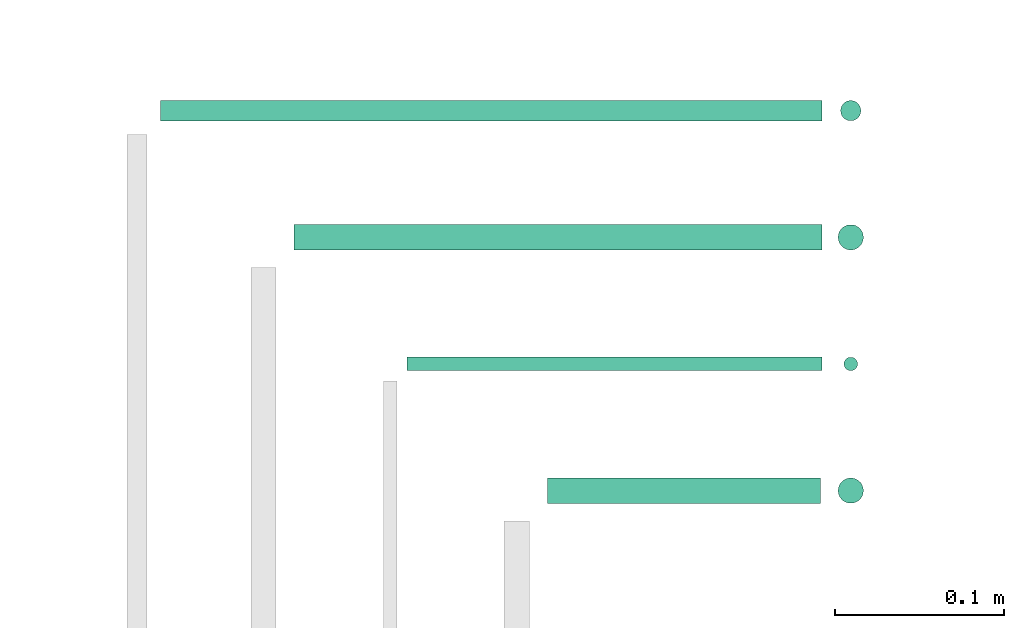
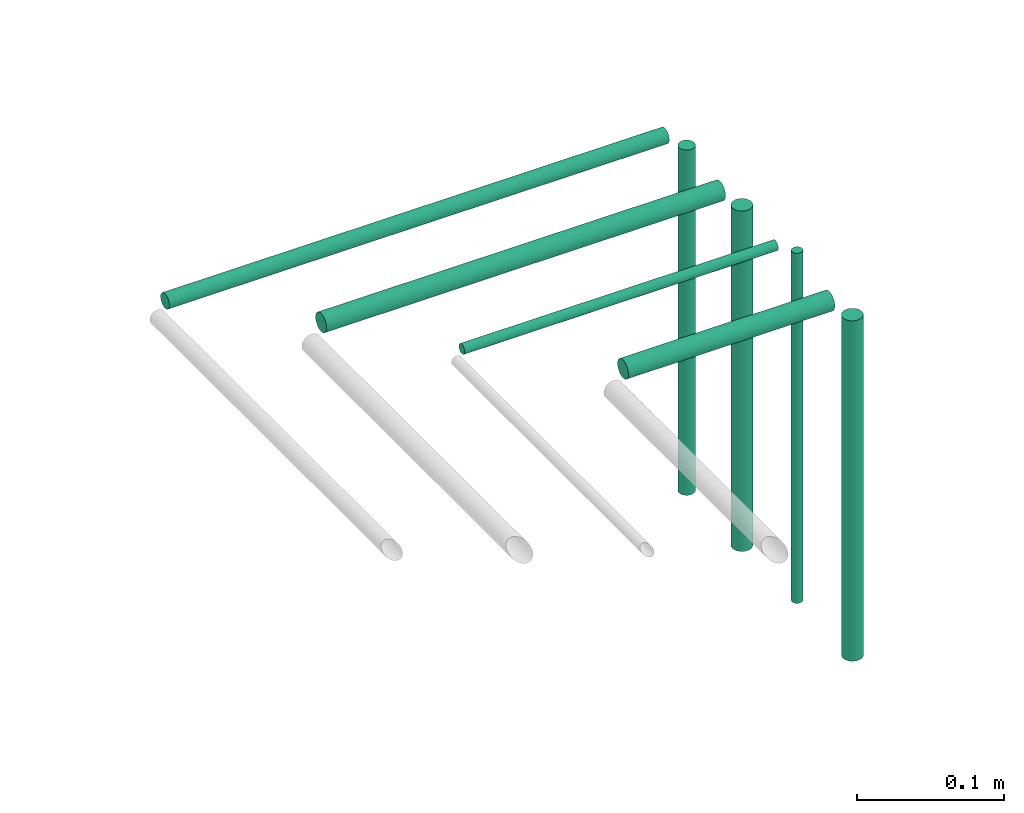
# One storey, part 35 of 65: 8 flow segments.
"""IFC2X3 building model written with IfcOpenShell, lengths in millimetres."""

from ifc_helpers import new_model, entity, si_unit, converted_unit, derived_unit, direction, frame, origin, origin_2d_with_axis, place, context, subcontext, project, spatial, circle, extrude, type_object, element, save


model = new_model("IFC2X3")

# Units and contexts
model_context = context("Model", 3, precision=0.01, world=origin(), true_north=direction((6.12303176911189e-17, 1.0)))
body_context = subcontext(model_context, "Body", "Model", "MODEL_VIEW")
ifc_project = project(units=[si_unit("LENGTHUNIT", "METRE", prefix="MILLI"), si_unit("AREAUNIT", "SQUARE_METRE"), si_unit("VOLUMEUNIT", "CUBIC_METRE"), converted_unit("PLANEANGLEUNIT", "DEGREE", entity("IfcRatioMeasure", 0.0174532925199433), si_unit("PLANEANGLEUNIT", "RADIAN"), dimensions=[0, 0, 0, 0, 0, 0, 0]), si_unit("MASSUNIT", "GRAM", prefix="KILO"), derived_unit("MASSDENSITYUNIT", [(si_unit("MASSUNIT", "GRAM", prefix="KILO"), 1), (si_unit("LENGTHUNIT", "METRE"), -3)]), derived_unit("MOMENTOFINERTIAUNIT", [(si_unit("LENGTHUNIT", "METRE"), 4)]), si_unit("TIMEUNIT", "SECOND"), si_unit("FREQUENCYUNIT", "HERTZ"), si_unit("THERMODYNAMICTEMPERATUREUNIT", "DEGREE_CELSIUS"), derived_unit("THERMALTRANSMITTANCEUNIT", [(si_unit("MASSUNIT", "GRAM", prefix="KILO"), 1), (si_unit("THERMODYNAMICTEMPERATUREUNIT", "KELVIN"), -1), (si_unit("TIMEUNIT", "SECOND"), -3)]), derived_unit("VOLUMETRICFLOWRATEUNIT", [(si_unit("LENGTHUNIT", "METRE"), 3), (si_unit("TIMEUNIT", "SECOND"), -1)]), derived_unit("MASSFLOWRATEUNIT", [(si_unit("MASSUNIT", "GRAM", prefix="KILO"), 1), (si_unit("TIMEUNIT", "SECOND"), -1)]), derived_unit("ROTATIONALFREQUENCYUNIT", [(si_unit("TIMEUNIT", "SECOND"), -1)]), si_unit("ELECTRICCURRENTUNIT", "AMPERE"), si_unit("ELECTRICVOLTAGEUNIT", "VOLT"), si_unit("POWERUNIT", "WATT"), si_unit("FORCEUNIT", "NEWTON", prefix="KILO"), si_unit("ILLUMINANCEUNIT", "LUX"), si_unit("LUMINOUSFLUXUNIT", "LUMEN"), si_unit("LUMINOUSINTENSITYUNIT", "CANDELA"), derived_unit("USERDEFINED", [(si_unit("MASSUNIT", "GRAM", prefix="KILO"), -1), (si_unit("LENGTHUNIT", "METRE"), -2), (si_unit("TIMEUNIT", "SECOND"), 3), (si_unit("LUMINOUSFLUXUNIT", "LUMEN"), 1)]), derived_unit("LINEARVELOCITYUNIT", [(si_unit("LENGTHUNIT", "METRE"), 1), (si_unit("TIMEUNIT", "SECOND"), -1)]), si_unit("PRESSUREUNIT", "PASCAL"), derived_unit("USERDEFINED", [(si_unit("LENGTHUNIT", "METRE"), -2), (si_unit("MASSUNIT", "GRAM", prefix="KILO"), 1), (si_unit("TIMEUNIT", "SECOND"), -2)]), derived_unit("LINEARFORCEUNIT", [(si_unit("MASSUNIT", "GRAM", prefix="KILO"), 1), (si_unit("LENGTHUNIT", "METRE"), 1), (si_unit("TIMEUNIT", "SECOND"), -2), (si_unit("LENGTHUNIT", "METRE"), -1)]), derived_unit("PLANARFORCEUNIT", [(si_unit("MASSUNIT", "GRAM", prefix="KILO"), 1), (si_unit("LENGTHUNIT", "METRE"), 1), (si_unit("TIMEUNIT", "SECOND"), -2), (si_unit("LENGTHUNIT", "METRE"), -2)])], contexts=[model_context])

# Site, building, storey
site_placement = place(None, frame((0.0, -0.00077364408347762, 0.0)))
site = spatial("IfcSite", under=ifc_project, at=site_placement, CompositionType="ELEMENT")
building_placement = place(site_placement, origin())
building = spatial("IfcBuilding", under=site, at=building_placement, CompositionType="ELEMENT")
storey_placement = place(building_placement, frame((0.0, 0.0, 19800.0)))
storey = spatial("IfcBuildingStorey", under=building, at=storey_placement, CompositionType="ELEMENT", Elevation=19800.0)

# Flow segments
pipe_segment_type = type_object("IfcPipeSegmentType", PredefinedType="NOTDEFINED")
flow_segment_1_placement = place(storey_placement, frame((37978.8041526611, 14430.591292662, 3140.90472776409)))
element("IfcFlowSegment", 1, at=flow_segment_1_placement, inside=storey, type_object=pipe_segment_type, context=body_context, shape_type="SweptSolid", body=[
    extrude(circle(Radius=7.5, at=origin_2d_with_axis()), frame((0.0, 9.09527223591853, 9.09527223591419), z_axis=(1.0, 0.0, 0.0), x_axis=(0.0, 1.0, 0.0)), (0.0, 0.0, 1.0), 161.73284503872),
])
flow_segment_2_placement = place(storey_placement, frame((37895.8041526611, 14509.091292662, 3144.40472776402)))
element("IfcFlowSegment", 2, at=flow_segment_2_placement, inside=storey, type_object=pipe_segment_type, context=body_context, shape_type="SweptSolid", body=[
    extrude(circle(Radius=4.0, at=origin_2d_with_axis()), frame((0.0, 5.59527223592365, 5.59527223591499), z_axis=(1.0, 0.0, 0.0), x_axis=(0.0, -1.0, 0.0)), (0.0, 0.0, 1.0), 245.732845038714),
])
flow_segment_3_placement = place(storey_placement, frame((38149.4417254639, 14430.591292662, 2850.0)))
element("IfcFlowSegment", 3, at=flow_segment_3_placement, inside=storey, type_object=pipe_segment_type, context=body_context, shape_type="SweptSolid", body=[
    extrude(circle(Radius=7.5, at=origin_2d_with_axis()), frame((9.09527223591419, 9.09527223591636, 0.0)), (0.0, 0.0, 1.0), 282.000000000005),
])
flow_segment_4_placement = place(storey_placement, frame((38152.9417254639, 14509.091292662, 2850.0)))
element("IfcFlowSegment", 4, at=flow_segment_4_placement, inside=storey, type_object=pipe_segment_type, context=body_context, shape_type="SweptSolid", body=[
    extrude(circle(Radius=4.0, at=origin_2d_with_axis()), frame((5.59527223591499, 5.59527223591499, 0.0)), (0.0, 0.0, 1.0), 290.000000000003),
])
flow_segment_5_placement = place(storey_placement, frame((37828.8041526611, 14580.591292662, 3140.90472776401)))
element("IfcFlowSegment", 5, at=flow_segment_5_placement, inside=storey, type_object=pipe_segment_type, context=body_context, shape_type="SweptSolid", body=[
    extrude(circle(Radius=7.5, at=origin_2d_with_axis()), frame((0.0, 9.09527223592936, 9.09527223591419), z_axis=(1.0, 0.0, 0.0), x_axis=(0.0, -1.0, 0.0)), (0.0, 0.0, 1.0), 312.732845038716),
])
flow_segment_6_placement = place(storey_placement, frame((38149.4417254639, 14580.591292662, 2850.0)))
element("IfcFlowSegment", 6, at=flow_segment_6_placement, inside=storey, type_object=pipe_segment_type, context=body_context, shape_type="SweptSolid", body=[
    extrude(circle(Radius=7.5, at=origin_2d_with_axis()), frame((9.09527223591419, 9.09527223591636, 0.0)), (0.0, 0.0, 1.0), 282.000000000005),
])
flow_segment_7_placement = place(storey_placement, frame((37749.8041526611, 14657.091292662, 3142.40472776401)))
element("IfcFlowSegment", 7, at=flow_segment_7_placement, inside=storey, type_object=pipe_segment_type, context=body_context, shape_type="SweptSolid", body=[
    extrude(circle(Radius=6.0, at=origin_2d_with_axis()), frame((0.0, 7.59527223593836, 7.59527223591454), z_axis=(1.0, 0.0, 0.0), x_axis=(0.0, -1.0, 0.0)), (0.0, 0.0, 1.0), 391.732845038716),
])
flow_segment_8_placement = place(storey_placement, frame((38150.9417254639, 14657.091292662, 2850.0)))
element("IfcFlowSegment", 8, at=flow_segment_8_placement, inside=storey, type_object=pipe_segment_type, context=body_context, shape_type="SweptSolid", body=[
    extrude(circle(Radius=6.0, at=origin_2d_with_axis()), frame((7.59527223591454, 7.5952722359167, 0.0)), (0.0, 0.0, 1.0), 286.000000000004),
])

save(model, "model.ifc")
